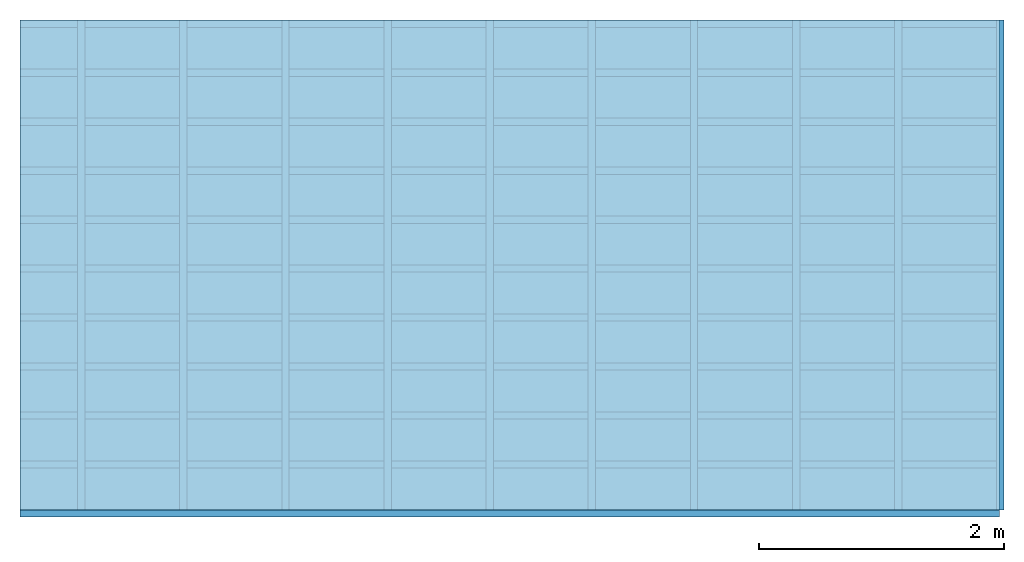
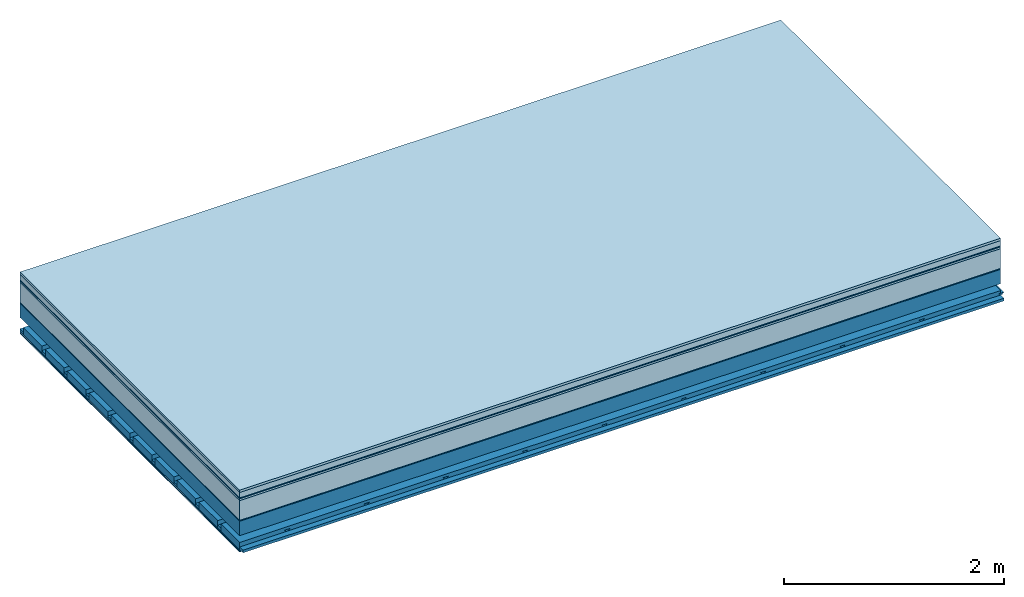
# One storey: 9 plates, 4 members, 1 element without a shape of its own.
"""IFC4 building model written with IfcOpenShell, lengths in metres."""

from ifc_helpers import new_model, si_unit, derived_unit, direction, frame, frame_2d, origin, origin_with_axes, place, context, project, spatial, polyline, rectangle, outline, extrude, material, layer, layer_set, type_object, element, aggregate, save


model = new_model("IFC4")

# Units and contexts
plan_context = context("Plan", 3, precision=1e-05, world=origin(), true_north=direction((0.0, 1.0)))
model_context = context("Model", 3, precision=1e-05, world=origin(), true_north=direction((0.0, 1.0)))
ifc_project = project(units=[si_unit("LENGTHUNIT", "METRE"), derived_unit("SOUNDPRESSUREUNIT", [(si_unit("PRESSUREUNIT", "PASCAL", prefix="MICRO"), 0)]), si_unit("ENERGYUNIT", "JOULE", prefix="MEGA"), si_unit("MASSUNIT", "GRAM", prefix="KILO"), derived_unit("THERMALTRANSMITTANCEUNIT", [(si_unit("POWERUNIT", "WATT"), 1), (si_unit("AREAUNIT", "SQUARE_METRE"), -1), (si_unit("THERMODYNAMICTEMPERATUREUNIT", "KELVIN"), -1)]), derived_unit("AREADENSITYUNIT", [(si_unit("MASSUNIT", "GRAM", prefix="KILO"), 1), (si_unit("AREAUNIT", "SQUARE_METRE"), -1)]), derived_unit("USERDEFINED", [(si_unit("ENERGYUNIT", "JOULE", prefix="MEGA"), 1), (si_unit("AREAUNIT", "SQUARE_METRE"), -1)])], contexts=[plan_context, model_context])

# Site, building, storey
site = spatial("IfcSite", under=ifc_project)
building_placement = place(None, origin())
building = spatial("IfcBuilding", under=site, at=building_placement)
storey_placement = place(building_placement, origin())
storey = spatial("IfcBuildingStorey", under=building, at=storey_placement)

# Slab, members, plates
ifc_material_1 = material(Category="07.009")
ifc_layer_1 = layer(ifc_material_1, 0.026, Name="Use and protection layer 3")
ifc_material_2 = material(Category="07.011")
ifc_layer_2 = layer(ifc_material_2, 0.06, Name="Use and protection layer 2")
ifc_material_3 = material(Name="Protective layer + Fire protection cover RF1", Category="09.007")
ifc_layer_3 = layer(ifc_material_3, 0.01, Name="Use and protection layer 1")
ifc_material_4 = material(Name="Bituminous", Category="09.003")
ifc_layer_4 = layer(ifc_material_4, 0.02, Name="Seal")
ifc_material_5 = material(Name="Mineral wool", Category="10.008")
ifc_layer_5 = layer(ifc_material_5, 0.22, Name="Exterior insulation layer 1")
ifc_material_6 = material(Name="Vapor-permeable barrier", Category="09.006")
ifc_layer_6 = layer(ifc_material_6, 0.01, Name="layer / temporary roof")
ifc_material_7 = material(Name="no composite action")
ifc_layer_7 = layer(ifc_material_7, 0.0, Name="Bond")
ifc_layer_8 = layer(None, 0.16, Name="Support")
ifc_layer_9 = layer(ifc_material_7, 0.0, Name="Bond")
ifc_layer_10 = layer(None, 0.125, Name="Coupling")
ifc_layer_11 = layer(None, 0.03, Name="Battens / profiles")
ifc_material_8 = material(Name="Plasterboard type A", Category="03.008")
ifc_layer_12 = layer(ifc_material_8, 0.0125, Name="Covering below 1st layer")
ifc_layer_13 = layer(ifc_material_8, 0.0125, Name="Covering below 2nd layer")
ifc_material_9 = material(Category="04.001")
ifc_layer_14 = layer(ifc_material_9, 0.003, Name="Surface below")
ifc_layer_set = layer_set([ifc_layer_1, ifc_layer_2, ifc_layer_3, ifc_layer_4, ifc_layer_5, ifc_layer_6, ifc_layer_7, ifc_layer_8, ifc_layer_9, ifc_layer_10, ifc_layer_11, ifc_layer_12, ifc_layer_13, ifc_layer_14])
slab_type = type_object("IfcSlabType", Name="F0070", PredefinedType="NOTDEFINED", material=ifc_layer_set)
slab_placement = place(None, frame((0.0, 0.0, 0.0), z_axis=(0.0, 0.0, -1.0), x_axis=(1.0, 0.0, 0.0)))
slab = element("IfcSlab", 1, at=slab_placement, inside=storey, type_object=slab_type, material=ifc_layer_set, Name="Slab #1")
ifc_material_10 = material(Name="Solid timber panel")
member_1_placement = place(slab_placement, origin())
member_1 = element("IfcMember", 2, at=member_1_placement, material=ifc_material_10, Name="Support", context=plan_context, shape_type="SweptSolid", body=[
    extrude(rectangle(XDim=1.0, YDim=0.16, at=frame_2d((0.5, 0.08), x_axis=(1.0, 0.0))), frame((0.0, 4.0, 0.346), z_axis=(0.0, -1.0, 0.0), x_axis=(1.0, 0.0, 0.0)), (0.0, 0.0, 1.0), 4.0),
    extrude(rectangle(XDim=1.0, YDim=0.16, at=frame_2d((0.5, 0.08), x_axis=(1.0, 0.0))), frame((1.0, 4.0, 0.346), z_axis=(0.0, -1.0, 0.0), x_axis=(1.0, 0.0, 0.0)), (0.0, 0.0, 1.0), 4.0),
    extrude(rectangle(XDim=1.0, YDim=0.16, at=frame_2d((0.5, 0.08), x_axis=(1.0, 0.0))), frame((2.0, 4.0, 0.346), z_axis=(0.0, -1.0, 0.0), x_axis=(1.0, 0.0, 0.0)), (0.0, 0.0, 1.0), 4.0),
    extrude(rectangle(XDim=1.0, YDim=0.16, at=frame_2d((0.5, 0.08), x_axis=(1.0, 0.0))), frame((3.0, 4.0, 0.346), z_axis=(0.0, -1.0, 0.0), x_axis=(1.0, 0.0, 0.0)), (0.0, 0.0, 1.0), 4.0),
    extrude(rectangle(XDim=1.0, YDim=0.16, at=frame_2d((0.5, 0.08), x_axis=(1.0, 0.0))), frame((4.0, 4.0, 0.346), z_axis=(0.0, -1.0, 0.0), x_axis=(1.0, 0.0, 0.0)), (0.0, 0.0, 1.0), 4.0),
    extrude(rectangle(XDim=1.0, YDim=0.16, at=frame_2d((0.5, 0.08), x_axis=(1.0, 0.0))), frame((5.0, 4.0, 0.346), z_axis=(0.0, -1.0, 0.0), x_axis=(1.0, 0.0, 0.0)), (0.0, 0.0, 1.0), 4.0),
    extrude(rectangle(XDim=1.0, YDim=0.16, at=frame_2d((0.5, 0.08), x_axis=(1.0, 0.0))), frame((6.0, 4.0, 0.346), z_axis=(0.0, -1.0, 0.0), x_axis=(1.0, 0.0, 0.0)), (0.0, 0.0, 1.0), 4.0),
    extrude(rectangle(XDim=1.0, YDim=0.16, at=frame_2d((0.5, 0.08), x_axis=(1.0, 0.0))), frame((7.0, 4.0, 0.346), z_axis=(0.0, -1.0, 0.0), x_axis=(1.0, 0.0, 0.0)), (0.0, 0.0, 1.0), 4.0),
])
ifc_material_11 = material()
member_2_placement = place(slab_placement, origin())
member_2 = element("IfcMember", 3, at=member_2_placement, material=ifc_material_11, Name="Coupling", context=plan_context, shape_type="SweptSolid", body=[
    extrude(outline(polyline([(0.0, 0.0), (0.06, 0.0), (0.04, 0.02), (0.02, 0.02), (0.0, 0.0)])), frame((0.47, 4.0, 0.611), z_axis=(0.0, -1.0, 0.0), x_axis=(1.0, 0.0, 0.0)), (0.0, 0.0, 1.0), 4.0),
    extrude(outline(polyline([(0.0, 0.0), (0.06, 0.0), (0.04, 0.02), (0.02, 0.02), (0.0, 0.0)])), frame((1.304, 4.0, 0.611), z_axis=(0.0, -1.0, 0.0), x_axis=(1.0, 0.0, 0.0)), (0.0, 0.0, 1.0), 4.0),
    extrude(outline(polyline([(0.0, 0.0), (0.06, 0.0), (0.04, 0.02), (0.02, 0.02), (0.0, 0.0)])), frame((2.138, 4.0, 0.611), z_axis=(0.0, -1.0, 0.0), x_axis=(1.0, 0.0, 0.0)), (0.0, 0.0, 1.0), 4.0),
    extrude(outline(polyline([(0.0, 0.0), (0.06, 0.0), (0.04, 0.02), (0.02, 0.02), (0.0, 0.0)])), frame((2.972, 4.0, 0.611), z_axis=(0.0, -1.0, 0.0), x_axis=(1.0, 0.0, 0.0)), (0.0, 0.0, 1.0), 4.0),
    extrude(outline(polyline([(0.0, 0.0), (0.06, 0.0), (0.04, 0.02), (0.02, 0.02), (0.0, 0.0)])), frame((3.806, 4.0, 0.611), z_axis=(0.0, -1.0, 0.0), x_axis=(1.0, 0.0, 0.0)), (0.0, 0.0, 1.0), 4.0),
    extrude(outline(polyline([(0.0, 0.0), (0.06, 0.0), (0.04, 0.02), (0.02, 0.02), (0.0, 0.0)])), frame((4.64, 4.0, 0.611), z_axis=(0.0, -1.0, 0.0), x_axis=(1.0, 0.0, 0.0)), (0.0, 0.0, 1.0), 4.0),
    extrude(outline(polyline([(0.0, 0.0), (0.06, 0.0), (0.04, 0.02), (0.02, 0.02), (0.0, 0.0)])), frame((5.474, 4.0, 0.611), z_axis=(0.0, -1.0, 0.0), x_axis=(1.0, 0.0, 0.0)), (0.0, 0.0, 1.0), 4.0),
    extrude(outline(polyline([(0.0, 0.0), (0.06, 0.0), (0.04, 0.02), (0.02, 0.02), (0.0, 0.0)])), frame((6.308, 4.0, 0.611), z_axis=(0.0, -1.0, 0.0), x_axis=(1.0, 0.0, 0.0)), (0.0, 0.0, 1.0), 4.0),
    extrude(outline(polyline([(0.0, 0.0), (0.06, 0.0), (0.04, 0.02), (0.02, 0.02), (0.0, 0.0)])), frame((7.142, 4.0, 0.611), z_axis=(0.0, -1.0, 0.0), x_axis=(1.0, 0.0, 0.0)), (0.0, 0.0, 1.0), 4.0),
    extrude(outline(polyline([(0.0, 0.0), (0.06, 0.0), (0.04, 0.02), (0.02, 0.02), (0.0, 0.0)])), frame((7.976, 4.0, 0.611), z_axis=(0.0, -1.0, 0.0), x_axis=(1.0, 0.0, 0.0)), (0.0, 0.0, 1.0), 4.0),
])
member_3_placement = place(slab_placement, origin())
member_3 = element("IfcMember", 4, at=member_3_placement, material=ifc_material_11, Name="Battens / profiles", context=plan_context, shape_type="SweptSolid", body=[
    extrude(rectangle(XDim=0.06, YDim=0.03, at=frame_2d((0.03, 0.015), x_axis=(1.0, 0.0))), frame((0.0, 0.0, 0.631), z_axis=(1.0, 0.0, 0.0), x_axis=(0.0, 1.0, 0.0)), (0.0, 0.0, 1.0), 8.0),
    extrude(rectangle(XDim=0.06, YDim=0.03, at=frame_2d((0.03, 0.015), x_axis=(1.0, 0.0))), frame((0.0, 0.4, 0.631), z_axis=(1.0, 0.0, 0.0), x_axis=(0.0, 1.0, 0.0)), (0.0, 0.0, 1.0), 8.0),
    extrude(rectangle(XDim=0.06, YDim=0.03, at=frame_2d((0.03, 0.015), x_axis=(1.0, 0.0))), frame((0.0, 0.8, 0.631), z_axis=(1.0, 0.0, 0.0), x_axis=(0.0, 1.0, 0.0)), (0.0, 0.0, 1.0), 8.0),
    extrude(rectangle(XDim=0.06, YDim=0.03, at=frame_2d((0.03, 0.015), x_axis=(1.0, 0.0))), frame((0.0, 1.2, 0.631), z_axis=(1.0, 0.0, 0.0), x_axis=(0.0, 1.0, 0.0)), (0.0, 0.0, 1.0), 8.0),
    extrude(rectangle(XDim=0.06, YDim=0.03, at=frame_2d((0.03, 0.015), x_axis=(1.0, 0.0))), frame((0.0, 1.6, 0.631), z_axis=(1.0, 0.0, 0.0), x_axis=(0.0, 1.0, 0.0)), (0.0, 0.0, 1.0), 8.0),
    extrude(rectangle(XDim=0.06, YDim=0.03, at=frame_2d((0.03, 0.015), x_axis=(1.0, 0.0))), frame((0.0, 2.0, 0.631), z_axis=(1.0, 0.0, 0.0), x_axis=(0.0, 1.0, 0.0)), (0.0, 0.0, 1.0), 8.0),
    extrude(rectangle(XDim=0.06, YDim=0.03, at=frame_2d((0.03, 0.015), x_axis=(1.0, 0.0))), frame((0.0, 2.4, 0.631), z_axis=(1.0, 0.0, 0.0), x_axis=(0.0, 1.0, 0.0)), (0.0, 0.0, 1.0), 8.0),
    extrude(rectangle(XDim=0.06, YDim=0.03, at=frame_2d((0.03, 0.015), x_axis=(1.0, 0.0))), frame((0.0, 2.8, 0.631), z_axis=(1.0, 0.0, 0.0), x_axis=(0.0, 1.0, 0.0)), (0.0, 0.0, 1.0), 8.0),
    extrude(rectangle(XDim=0.06, YDim=0.03, at=frame_2d((0.03, 0.015), x_axis=(1.0, 0.0))), frame((0.0, 3.2, 0.631), z_axis=(1.0, 0.0, 0.0), x_axis=(0.0, 1.0, 0.0)), (0.0, 0.0, 1.0), 8.0),
    extrude(rectangle(XDim=0.06, YDim=0.03, at=frame_2d((0.03, 0.015), x_axis=(1.0, 0.0))), frame((0.0, 3.6, 0.631), z_axis=(1.0, 0.0, 0.0), x_axis=(0.0, 1.0, 0.0)), (0.0, 0.0, 1.0), 8.0),
    extrude(rectangle(XDim=0.06, YDim=0.03, at=frame_2d((0.03, 0.015), x_axis=(1.0, 0.0))), frame((0.0, 4.0, 0.631), z_axis=(1.0, 0.0, 0.0), x_axis=(0.0, 1.0, 0.0)), (0.0, 0.0, 1.0), 8.0),
])
ifc_material_12 = material()
member_4_placement = place(slab_placement, origin())
member_4 = element("IfcMember", 5, at=member_4_placement, material=ifc_material_12, Name="Cavity", context=plan_context, shape_type="SweptSolid", body=[
    extrude(rectangle(XDim=0.34, YDim=0.08, at=frame_2d((0.17, 0.04), x_axis=(1.0, 0.0))), frame((0.0, 0.06, 0.581), z_axis=(1.0, 0.0, 0.0), x_axis=(0.0, 1.0, 0.0)), (0.0, 0.0, 1.0), 8.0),
    extrude(rectangle(XDim=0.34, YDim=0.08, at=frame_2d((0.17, 0.04), x_axis=(1.0, 0.0))), frame((0.0, 0.46, 0.581), z_axis=(1.0, 0.0, 0.0), x_axis=(0.0, 1.0, 0.0)), (0.0, 0.0, 1.0), 8.0),
    extrude(rectangle(XDim=0.34, YDim=0.08, at=frame_2d((0.17, 0.04), x_axis=(1.0, 0.0))), frame((0.0, 0.86, 0.581), z_axis=(1.0, 0.0, 0.0), x_axis=(0.0, 1.0, 0.0)), (0.0, 0.0, 1.0), 8.0),
    extrude(rectangle(XDim=0.34, YDim=0.08, at=frame_2d((0.17, 0.04), x_axis=(1.0, 0.0))), frame((0.0, 1.26, 0.581), z_axis=(1.0, 0.0, 0.0), x_axis=(0.0, 1.0, 0.0)), (0.0, 0.0, 1.0), 8.0),
    extrude(rectangle(XDim=0.34, YDim=0.08, at=frame_2d((0.17, 0.04), x_axis=(1.0, 0.0))), frame((0.0, 1.66, 0.581), z_axis=(1.0, 0.0, 0.0), x_axis=(0.0, 1.0, 0.0)), (0.0, 0.0, 1.0), 8.0),
    extrude(rectangle(XDim=0.34, YDim=0.08, at=frame_2d((0.17, 0.04), x_axis=(1.0, 0.0))), frame((0.0, 2.06, 0.581), z_axis=(1.0, 0.0, 0.0), x_axis=(0.0, 1.0, 0.0)), (0.0, 0.0, 1.0), 8.0),
    extrude(rectangle(XDim=0.34, YDim=0.08, at=frame_2d((0.17, 0.04), x_axis=(1.0, 0.0))), frame((0.0, 2.46, 0.581), z_axis=(1.0, 0.0, 0.0), x_axis=(0.0, 1.0, 0.0)), (0.0, 0.0, 1.0), 8.0),
    extrude(rectangle(XDim=0.34, YDim=0.08, at=frame_2d((0.17, 0.04), x_axis=(1.0, 0.0))), frame((0.0, 2.86, 0.581), z_axis=(1.0, 0.0, 0.0), x_axis=(0.0, 1.0, 0.0)), (0.0, 0.0, 1.0), 8.0),
    extrude(rectangle(XDim=0.34, YDim=0.08, at=frame_2d((0.17, 0.04), x_axis=(1.0, 0.0))), frame((0.0, 3.26, 0.581), z_axis=(1.0, 0.0, 0.0), x_axis=(0.0, 1.0, 0.0)), (0.0, 0.0, 1.0), 8.0),
    extrude(rectangle(XDim=0.34, YDim=0.08, at=frame_2d((0.17, 0.04), x_axis=(1.0, 0.0))), frame((0.0, 3.66, 0.581), z_axis=(1.0, 0.0, 0.0), x_axis=(0.0, 1.0, 0.0)), (0.0, 0.0, 1.0), 8.0),
])
plate_1_placement = place(slab_placement, origin())
plate_1 = element("IfcPlate", 6, at=plate_1_placement, material=ifc_material_1, Name="Use and protection layer 3", context=plan_context, shape_type="SweptSolid", body=[
    extrude(rectangle(XDim=8.0, YDim=4.0, at=frame_2d((4.0, 2.0), x_axis=(1.0, 0.0))), origin_with_axes(), (0.0, 0.0, 1.0), 0.026),
])
plate_2_placement = place(slab_placement, origin())
plate_2 = element("IfcPlate", 7, at=plate_2_placement, material=ifc_material_2, Name="Use and protection layer 2", context=plan_context, shape_type="SweptSolid", body=[
    extrude(rectangle(XDim=8.0, YDim=4.0, at=frame_2d((4.0, 2.0), x_axis=(1.0, 0.0))), frame((0.0, 0.0, 0.026), z_axis=(0.0, 0.0, 1.0), x_axis=(1.0, 0.0, 0.0)), (0.0, 0.0, 1.0), 0.06),
])
plate_3_placement = place(slab_placement, origin())
plate_3 = element("IfcPlate", 8, at=plate_3_placement, material=ifc_material_3, Name="Use and protection layer 1", context=plan_context, shape_type="SweptSolid", body=[
    extrude(rectangle(XDim=8.0, YDim=4.0, at=frame_2d((4.0, 2.0), x_axis=(1.0, 0.0))), frame((0.0, 0.0, 0.086), z_axis=(0.0, 0.0, 1.0), x_axis=(1.0, 0.0, 0.0)), (0.0, 0.0, 1.0), 0.01),
])
plate_4_placement = place(slab_placement, origin())
plate_4 = element("IfcPlate", 9, at=plate_4_placement, material=ifc_material_4, Name="Seal", context=plan_context, shape_type="SweptSolid", body=[
    extrude(rectangle(XDim=8.0, YDim=4.0, at=frame_2d((4.0, 2.0), x_axis=(1.0, 0.0))), frame((0.0, 0.0, 0.096), z_axis=(0.0, 0.0, 1.0), x_axis=(1.0, 0.0, 0.0)), (0.0, 0.0, 1.0), 0.02),
])
plate_5_placement = place(slab_placement, origin())
plate_5 = element("IfcPlate", 10, at=plate_5_placement, material=ifc_material_5, Name="Exterior insulation layer 1", context=plan_context, shape_type="SweptSolid", body=[
    extrude(rectangle(XDim=8.0, YDim=4.0, at=frame_2d((4.0, 2.0), x_axis=(1.0, 0.0))), frame((0.0, 0.0, 0.116), z_axis=(0.0, 0.0, 1.0), x_axis=(1.0, 0.0, 0.0)), (0.0, 0.0, 1.0), 0.22),
])
plate_6_placement = place(slab_placement, origin())
plate_6 = element("IfcPlate", 11, at=plate_6_placement, material=ifc_material_6, Name="layer / temporary roof", context=plan_context, shape_type="SweptSolid", body=[
    extrude(rectangle(XDim=8.0, YDim=4.0, at=frame_2d((4.0, 2.0), x_axis=(1.0, 0.0))), frame((0.0, 0.0, 0.336), z_axis=(0.0, 0.0, 1.0), x_axis=(1.0, 0.0, 0.0)), (0.0, 0.0, 1.0), 0.01),
])
plate_7_placement = place(slab_placement, origin())
plate_7 = element("IfcPlate", 12, at=plate_7_placement, material=ifc_material_8, Name="Covering below 1st layer", context=plan_context, shape_type="SweptSolid", body=[
    extrude(rectangle(XDim=8.0, YDim=4.0, at=frame_2d((4.0, 2.0), x_axis=(1.0, 0.0))), frame((0.0, 0.0, 0.661), z_axis=(0.0, 0.0, 1.0), x_axis=(1.0, 0.0, 0.0)), (0.0, 0.0, 1.0), 0.0125),
])
plate_8_placement = place(slab_placement, origin())
plate_8 = element("IfcPlate", 13, at=plate_8_placement, material=ifc_material_8, Name="Covering below 2nd layer", context=plan_context, shape_type="SweptSolid", body=[
    extrude(rectangle(XDim=8.0, YDim=4.0, at=frame_2d((4.0, 2.0), x_axis=(1.0, 0.0))), frame((0.0, 0.0, 0.6735), z_axis=(0.0, 0.0, 1.0), x_axis=(1.0, 0.0, 0.0)), (0.0, 0.0, 1.0), 0.0125),
])
plate_9_placement = place(slab_placement, origin())
plate_9 = element("IfcPlate", 14, at=plate_9_placement, material=ifc_material_9, Name="Surface below", context=plan_context, shape_type="SweptSolid", body=[
    extrude(rectangle(XDim=8.0, YDim=4.0, at=frame_2d((4.0, 2.0), x_axis=(1.0, 0.0))), frame((0.0, 0.0, 0.686), z_axis=(0.0, 0.0, 1.0), x_axis=(1.0, 0.0, 0.0)), (0.0, 0.0, 1.0), 0.003),
])
aggregate(slab, [plate_1, plate_2, plate_3, plate_4, plate_5, plate_6, member_1, member_2, member_3, member_4, plate_7, plate_8, plate_9])

save(model, "model.ifc")
